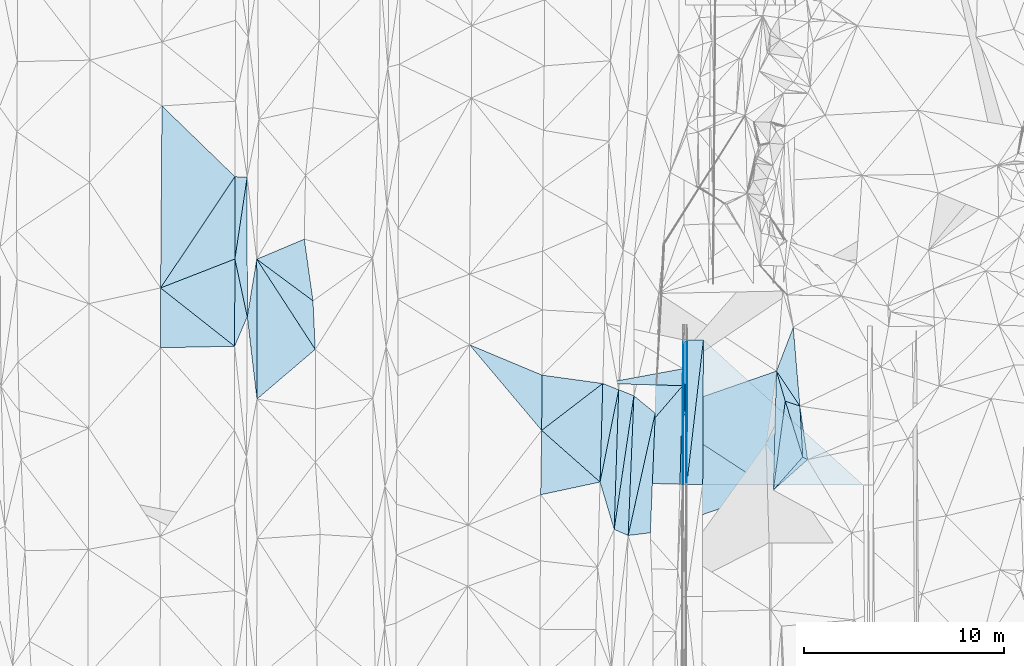
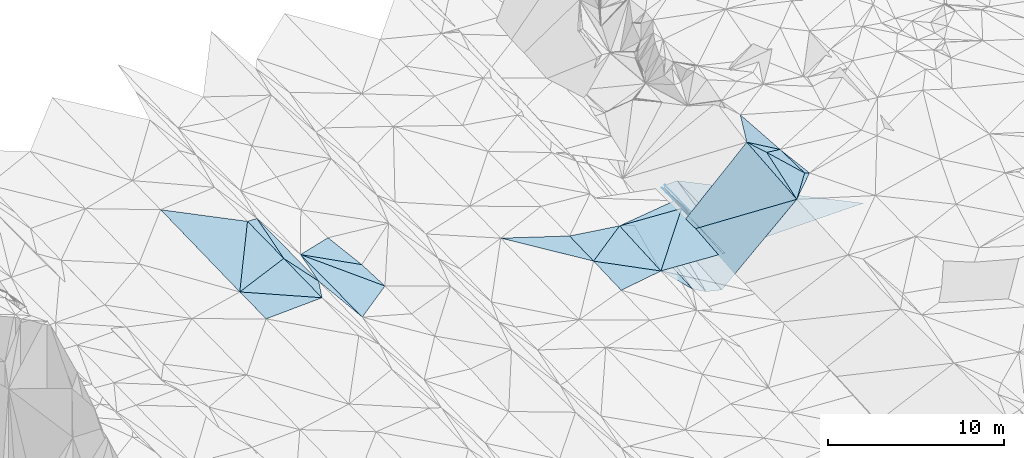
# One storey, part 147 of 275: 45 plates.
"""IFC2X3 building model written with IfcOpenShell, lengths in millimetres."""

from ifc_helpers import new_model, si_unit, frame, origin_with_axes, place, context, subcontext, project, spatial, polyline, outline, extrude, material, type_object, element, save


model = new_model("IFC2X3")

# Units and contexts
model_context = context("Model", 3, precision=1e-05, world=origin_with_axes())
body_context = subcontext(model_context, "Body", "Model", "MODEL_VIEW")
ifc_project = project(units=[si_unit("LENGTHUNIT", "METRE", prefix="MILLI"), si_unit("AREAUNIT", "SQUARE_METRE"), si_unit("VOLUMEUNIT", "CUBIC_METRE"), si_unit("MASSUNIT", "GRAM", prefix="KILO"), si_unit("TIMEUNIT", "SECOND"), si_unit("PLANEANGLEUNIT", "RADIAN"), si_unit("SOLIDANGLEUNIT", "STERADIAN"), si_unit("THERMODYNAMICTEMPERATUREUNIT", "DEGREE_CELSIUS"), si_unit("LUMINOUSINTENSITYUNIT", "LUMEN")], contexts=[model_context])

# Site, building, storey
site_placement = place(None, origin_with_axes())
site = spatial("IfcSite", under=ifc_project, at=site_placement, CompositionType="ELEMENT")
building_placement = place(site_placement, origin_with_axes())
building = spatial("IfcBuilding", under=site, at=building_placement, Name="Undefined", CompositionType="ELEMENT")
storey_placement = place(building_placement, origin_with_axes())
storey = spatial("IfcBuildingStorey", under=building, at=storey_placement, Name="Undefined", CompositionType="ELEMENT", Elevation=0.0)

# Plates
ifc_material = material()
plate_type_1 = type_object("IfcPlateType", PredefinedType="NOTDEFINED")
plate_1_placement = place(storey_placement, frame((-56559.9094753957, 108873.077554814, 43296.3051674812), z_axis=(0.0200615901055505, 0.0163078919971545, -0.999665736764568), x_axis=(0.00478614400087478, 0.999853940724789, 0.0164070119983152)))
element("IfcPlate", 1, at=plate_1_placement, inside=storey, type_object=plate_type_1, material=ifc_material, Name="00_PR", context=body_context, shape_type="SweptSolid", body=[
    extrude(outline(polyline([(0.0, 0.0), (7237.02734375, -3.50992195308208e-08), (7.50920295715332, 8049.544921875), (0.0, 0.0)])), frame((-8.85201319254618e-08, 2.18876761149539e-07, -0.5000001331573), z_axis=(0.0, 0.0, 1.0), x_axis=(1.0, 0.0, 0.0)), (0.0, 0.0, 1.0), 1.0),
])
plate_type_2 = type_object("IfcPlateType", PredefinedType="NOTDEFINED")
plate_2_placement = place(storey_placement, frame((-53025.702382327, 108590.22284917, 45459.5055178758), z_axis=(0.136982781048721, 0.0570289209875159, -0.988930442380635), x_axis=(0.133069726315473, 0.988232827930572, 0.0754209900403692)))
element("IfcPlate", 2, at=plate_2_placement, inside=storey, type_object=plate_type_2, material=ifc_material, Name="00", context=body_context, shape_type="SweptSolid", body=[
    extrude(outline(polyline([(0.0, 0.0), (4508.02880859375, -2.83034751191735e-09), (1859.37231445313, 1250.28735351563), (0.0, 0.0)])), frame((-8.85201319254618e-08, 2.18876761149539e-07, -0.5000001331573), z_axis=(0.0, 0.0, 1.0), x_axis=(1.0, 0.0, 0.0)), (0.0, 0.0, 1.0), 1.0),
])
plate_type_3 = type_object("IfcPlateType", PredefinedType="NOTDEFINED")
plate_3_placement = place(storey_placement, frame((-61564.7340674209, 113931.656635137, 43369.5003387347), z_axis=(-0.031872588093032, 0.0183197905834764, -0.999324033235081), x_axis=(0.983091267140744, 0.18095706105248, -0.028037519984031)))
element("IfcPlate", 3, at=plate_3_placement, inside=storey, type_object=plate_type_3, material=ifc_material, Name="00_PR", context=body_context, shape_type="SweptSolid", body=[
    extrude(outline(polyline([(0.0, 0.0), (4091.7314453125, -9.50240064412355e-09), (3914.64038085938, 832.093811035156), (0.0, 0.0)])), frame((-8.85201319254618e-08, 2.18876761149539e-07, -0.5000001331573), z_axis=(0.0, 0.0, 1.0), x_axis=(1.0, 0.0, 0.0)), (0.0, 0.0, 1.0), 1.0),
])
plate_type_4 = type_object("IfcPlateType", PredefinedType="NOTDEFINED")
plate_4_placement = place(storey_placement, frame((-57566.2411546469, 113821.823646722, 43239.9583379876), z_axis=(-0.0318749769075172, 0.0182345515766572, -0.999325516023655), x_axis=(-0.650509884848787, -0.759466524871226, 0.00689110397837056)))
element("IfcPlate", 4, at=plate_4_placement, inside=storey, type_object=plate_type_4, material=ifc_material, Name="00_PR", context=body_context, shape_type="SweptSolid", body=[
    extrude(outline(polyline([(0.0, 0.0), (6355.1494140625, -1.87283148989081e-08), (2518.53735351563, 3110.26684570313), (0.0, 0.0)])), frame((-8.85201319254618e-08, 2.18876761149539e-07, -0.5000001331573), z_axis=(0.0, 0.0, 1.0), x_axis=(1.0, 0.0, 0.0)), (0.0, 0.0, 1.0), 1.0),
])
plate_type_5 = type_object("IfcPlateType", PredefinedType="NOTDEFINED")
plate_5_placement = place(storey_placement, frame((-61700.3286359968, 108995.300084847, 43283.7523294641), z_axis=(-0.0315213256093392, 0.0179314852149467, -0.999342217596063), x_axis=(0.650509884845149, 0.759466524874353, -0.00689110397720621)))
element("IfcPlate", 5, at=plate_5_placement, inside=storey, type_object=plate_type_5, material=ifc_material, Name="00_PR", context=body_context, shape_type="SweptSolid", body=[
    extrude(outline(polyline([(0.0, 0.0), (6355.1494140625, -1.87283148989081e-08), (2516.81982421875, 3111.59790039063), (0.0, 0.0)])), frame((-8.85201319254618e-08, 2.18876761149539e-07, -0.5000001331573), z_axis=(0.0, 0.0, 1.0), x_axis=(1.0, 0.0, 0.0)), (0.0, 0.0, 1.0), 1.0),
])
plate_type_6 = type_object("IfcPlateType", PredefinedType="NOTDEFINED")
plate_6_placement = place(storey_placement, frame((-57541.6876743928, 114672.07483175, 43255.1567316747), z_axis=(0.97014205143925, -0.000664742498379552, -0.242536508894339), x_axis=(0.0281062970175197, 0.993567110422901, 0.109701564044688)))
element("IfcPlate", 6, at=plate_6_placement, inside=storey, type_object=plate_type_6, material=ifc_material, Name="00_PR", context=body_context, shape_type="SweptSolid", body=[
    extrude(outline(polyline([(0.0, 0.0), (1284.78564453125, -4.48198989033699e-09), (-5754.66259765625, 680.785278320313), (0.0, 0.0)])), frame((-8.85201319254618e-08, 2.18876761149539e-07, -0.5000001331573), z_axis=(0.0, 0.0, 1.0), x_axis=(1.0, 0.0, 0.0)), (0.0, 0.0, 1.0), 1.0),
])
plate_7_placement = place(storey_placement, frame((-57541.6876743928, 114672.07483175, 43255.1567316747), z_axis=(0.970141058159166, -0.000664759863565607, -0.24254048191619), x_axis=(0.000390214973503227, -0.999990671851025, 0.00430162099806109)))
element("IfcPlate", 7, at=plate_7_placement, inside=storey, type_object=plate_type_6, material=ifc_material, Name="00_PR", context=body_context, shape_type="SweptSolid", body=[
    extrude(outline(polyline([(0.0, 0.0), (5794.7919921875, -1.07320374809206e-09), (5792.109375, 123.645538330078), (0.0, 0.0)])), frame((-8.85201319254618e-08, 2.18876761149539e-07, -0.5000001331573), z_axis=(0.0, 0.0, 1.0), x_axis=(1.0, 0.0, 0.0)), (0.0, 0.0, 1.0), 1.0),
])
plate_type_7 = type_object("IfcPlateType", PredefinedType="NOTDEFINED")
plate_8_placement = place(storey_placement, frame((-57506.0621338796, 115948.60418002, 43395.72106721), z_axis=(8.71486001612448e-05, 0.0164040720423197, -0.999865440359628), x_axis=(0.0164193319999173, -0.999730679449421, -0.0164004300027693)))
element("IfcPlate", 8, at=plate_8_placement, inside=storey, type_object=plate_type_7, material=ifc_material, Name="00_PR", context=body_context, shape_type="SweptSolid", body=[
    extrude(outline(polyline([(0.0, 0.0), (7073.96044921875, 4.65661287307739e-10), (7070.701171875, 149.965759277344), (0.0, 0.0)])), frame((-8.85201319254618e-08, 2.18876761149539e-07, -0.5000001331573), z_axis=(0.0, 0.0, 1.0), x_axis=(1.0, 0.0, 0.0)), (0.0, 0.0, 1.0), 1.0),
])
plate_9_placement = place(storey_placement, frame((-57506.0621338796, 115948.60418002, 43395.72106721), z_axis=(0.000108002750360124, 0.0164041444367086, -0.999865437136771), x_axis=(0.674741321812781, 0.737953789828376, 0.0121800129835136)))
element("IfcPlate", 9, at=plate_9_placement, inside=storey, type_object=plate_type_7, material=ifc_material, Name="00_PR", context=body_context, shape_type="SweptSolid", body=[
    extrude(outline(polyline([(0.0, 0.0), (223.480865478516, 2.61934474110603e-10), (-5141.89208984375, 4858.1748046875), (0.0, 0.0)])), frame((-8.85201319254618e-08, 2.18876761149539e-07, -0.5000001331573), z_axis=(0.0, 0.0, 1.0), x_axis=(1.0, 0.0, 0.0)), (0.0, 0.0, 1.0), 1.0),
])
plate_type_8 = type_object("IfcPlateType", PredefinedType="NOTDEFINED")
plate_10_placement = place(storey_placement, frame((-57542.1509980712, 114672.083254713, 43254.7785386739), z_axis=(0.0434943675929681, 0.0161807870784068, -0.998922630696297), x_axis=(-0.0047862770141317, -0.999853985013347, -0.0164042739941027)))
element("IfcPlate", 10, at=plate_10_placement, inside=storey, type_object=plate_type_8, material=ifc_material, Name="00_PR", context=body_context, shape_type="SweptSolid", body=[
    extrude(outline(polyline([(0.0, 0.0), (5793.42919921875, -3.92756192013621e-08), (850.494689941406, 20.0009212493896), (0.0, 0.0)])), frame((-8.85201319254618e-08, 2.18876761149539e-07, -0.5000001331573), z_axis=(0.0, 0.0, 1.0), x_axis=(1.0, 0.0, 0.0)), (0.0, 0.0, 1.0), 1.0),
])
plate_type_9 = type_object("IfcPlateType", PredefinedType="NOTDEFINED")
plate_11_placement = place(storey_placement, frame((-57506.0473725171, 115948.6041072, 43276.6102854014), z_axis=(0.0296062397546576, 0.016255470394761, -0.999429452362614), x_axis=(-0.0282728290321434, -0.999454082377336, -0.0170934010014322)))
element("IfcPlate", 11, at=plate_11_placement, inside=storey, type_object=plate_type_9, material=ifc_material, Name="00_PR", context=body_context, shape_type="SweptSolid", body=[
    extrude(outline(polyline([(0.0, 0.0), (1277.21801757813, -4.40923031419516e-09), (-165.004837036133, 33.8989753723145), (0.0, 0.0)])), frame((-8.85201319254618e-08, 2.18876761149539e-07, -0.5000001331573), z_axis=(0.0, 0.0, 1.0), x_axis=(1.0, 0.0, 0.0)), (0.0, 0.0, 1.0), 1.0),
])
plate_12_placement = place(storey_placement, frame((-57325.2602877436, 116113.361240939, 43399.0431664124), z_axis=(0.0200810104117141, 0.0163055986180557, -0.999665384253427), x_axis=(-0.0047862770141317, -0.999853985013347, -0.0164042739941027)))
element("IfcPlate", 12, at=plate_12_placement, inside=storey, type_object=plate_type_9, material=ifc_material, Name="00_PR", context=body_context, shape_type="SweptSolid", body=[
    extrude(outline(polyline([(0.0, 0.0), (7237.9951171875, 2.11512087844312e-08), (-0.00799687579274178, 30.0065059661865), (0.0, 0.0)])), frame((-8.85201319254618e-08, 2.18876761149539e-07, -0.5000001331573), z_axis=(0.0, 0.0, 1.0), x_axis=(1.0, 0.0, 0.0)), (0.0, 0.0, 1.0), 1.0),
])
plate_13_placement = place(storey_placement, frame((-57389.9024439034, 108876.548616572, 43279.7051689507), z_axis=(0.0200618970811728, 0.0163056173507373, -0.999665767708546), x_axis=(0.00478621599944913, 0.999853976363839, 0.0164048189818349)))
element("IfcPlate", 13, at=plate_13_placement, inside=storey, type_object=plate_type_9, material=ifc_material, Name="00_PR", context=body_context, shape_type="SweptSolid", body=[
    extrude(outline(polyline([(0.0, 0.0), (7238.03076171875, 4.33428795076907e-08), (0.0278349369764328, 30.0057830810547), (0.0, 0.0)])), frame((-8.85201319254618e-08, 2.18876761149539e-07, -0.5000001331573), z_axis=(0.0, 0.0, 1.0), x_axis=(1.0, 0.0, 0.0)), (0.0, 0.0, 1.0), 1.0),
])
plate_type_10 = type_object("IfcPlateType", PredefinedType="NOTDEFINED")
plate_14_placement = place(storey_placement, frame((-57569.8858779446, 108879.50010041, 43159.7413161751), z_axis=(0.0316447606239588, 0.0161968292202808, -0.999367936171789), x_axis=(-0.999106465482098, 0.028538662990022, -0.0311739530154894)))
element("IfcPlate", 14, at=plate_14_placement, inside=storey, type_object=plate_type_10, material=ifc_material, Name="00_PR", context=body_context, shape_type="SweptSolid", body=[
    extrude(outline(polyline([(0.0, 0.0), (132.097457885742, -2.47382558882236e-10), (134.873397827148, 4941.13427734375), (0.0, 0.0)])), frame((-8.85201319254618e-08, 2.18876761149539e-07, -0.5000001331573), z_axis=(0.0, 0.0, 1.0), x_axis=(1.0, 0.0, 0.0)), (0.0, 0.0, 1.0), 1.0),
])
plate_type_11 = type_object("IfcPlateType", PredefinedType="NOTDEFINED")
plate_15_placement = place(storey_placement, frame((-61700.3298359356, 108995.299158409, 43279.5003424583), z_axis=(-0.0336503728996484, 0.0160114540032041, -0.999305401638767), x_axis=(-0.977366811814585, -0.209476972524514, 0.0295552557992385)))
element("IfcPlate", 15, at=plate_15_placement, inside=storey, type_object=plate_type_11, material=ifc_material, Name="00", context=body_context, shape_type="SweptSolid", body=[
    extrude(outline(polyline([(0.0, 0.0), (3045.1435546875, -5.73345459997654e-09), (2322.05786132813, 3144.36743164063), (0.0, 0.0)])), frame((-8.85201319254618e-08, 2.18876761149539e-07, -0.5000001331573), z_axis=(0.0, 0.0, 1.0), x_axis=(1.0, 0.0, 0.0)), (0.0, 0.0, 1.0), 1.0),
])
plate_type_12 = type_object("IfcPlateType", PredefinedType="NOTDEFINED")
plate_16_placement = place(storey_placement, frame((-56525.2720170413, 116109.048059922, 43415.0431675698), z_axis=(0.0200615901055505, 0.0163078919971545, -0.999665736764568), x_axis=(-0.00478614402044619, -0.999853940724827, -0.0164070119903158)))
element("IfcPlate", 16, at=plate_16_placement, inside=storey, type_object=plate_type_12, material=ifc_material, Name="00_PR", context=body_context, shape_type="SweptSolid", body=[
    extrude(outline(polyline([(0.0, 0.0), (7237.02734375, -3.50992195308208e-08), (7237.77392578125, 800.160034179688), (0.0, 0.0)])), frame((-8.85201319254618e-08, 2.18876761149539e-07, -0.5000001331573), z_axis=(0.0, 0.0, 1.0), x_axis=(1.0, 0.0, 0.0)), (0.0, 0.0, 1.0), 1.0),
])
plate_17_placement = place(storey_placement, frame((-57359.9028967669, 108876.423013428, 43280.3051665341), z_axis=(0.0200810104117141, 0.0163055986180557, -0.999665384253427), x_axis=(0.00478621599944913, 0.999853976363839, 0.0164048189818349)))
element("IfcPlate", 17, at=plate_17_placement, inside=storey, type_object=plate_type_12, material=ifc_material, Name="00_PR", context=body_context, shape_type="SweptSolid", body=[
    extrude(outline(polyline([(0.0, 0.0), (7237.9951171875, 2.11512087844312e-08), (7237.77392578125, 800.159851074219), (0.0, 0.0)])), frame((-8.85201319254618e-08, 2.18876761149539e-07, -0.5000001331573), z_axis=(0.0, 0.0, 1.0), x_axis=(1.0, 0.0, 0.0)), (0.0, 0.0, 1.0), 1.0),
])
plate_type_13 = type_object("IfcPlateType", PredefinedType="NOTDEFINED")
plate_18_placement = place(storey_placement, frame((-52866.5394880379, 114551.624411955, 45750.5104493135), z_axis=(0.197561966360912, 0.0489440177551858, -0.979067797741091), x_axis=(0.355493649309711, 0.927189514081718, 0.118084166073915)))
element("IfcPlate", 18, at=plate_18_placement, inside=storey, type_object=plate_type_13, material=ifc_material, Name="00", context=body_context, shape_type="SweptSolid", body=[
    extrude(outline(polyline([(0.0, 0.0), (2362.72143554688, -1.17579475045204e-08), (-1189.66076660156, 1746.19018554688), (0.0, 0.0)])), frame((-8.85201319254618e-08, 2.18876761149539e-07, -0.5000001331573), z_axis=(0.0, 0.0, 1.0), x_axis=(1.0, 0.0, 0.0)), (0.0, 0.0, 1.0), 1.0),
])
plate_type_14 = type_object("IfcPlateType", PredefinedType="NOTDEFINED")
plate_19_placement = place(storey_placement, frame((-64626.5653119508, 111583.077539829, 43419.5006351071), z_axis=(-0.04572592766013, 0.0220578004179306, -0.998710465039965), x_axis=(-0.643676725618658, 0.763893098718301, 0.0463422768904888)))
element("IfcPlate", 19, at=plate_19_placement, inside=storey, type_object=plate_type_14, material=ifc_material, Name="00", context=body_context, shape_type="SweptSolid", body=[
    extrude(outline(polyline([(0.0, 0.0), (5610.427734375, 2.36650521401316e-08), (2100.267578125, 1800.68762207031), (0.0, 0.0)])), frame((-8.85201319254618e-08, 2.18876761149539e-07, -0.5000001331573), z_axis=(0.0, 0.0, 1.0), x_axis=(1.0, 0.0, 0.0)), (0.0, 0.0, 1.0), 1.0),
])
plate_type_15 = type_object("IfcPlateType", PredefinedType="NOTDEFINED")
plate_20_placement = place(storey_placement, frame((-60994.8887578139, 106625.212762836, 43220.5259557587), z_axis=(-0.31707448824831, 0.0250206523563712, -0.948070533166037), x_axis=(0.032295426454886, 0.999357033452528, 0.0155732180059018)))
element("IfcPlate", 20, at=plate_20_placement, inside=storey, type_object=plate_type_15, material=ifc_material, Name="00", context=body_context, shape_type="SweptSolid", body=[
    extrude(outline(polyline([(0.0, 0.0), (6999.19580078125, 2.98750819638371e-08), (6715.134765625, 813.955322265625), (0.0, 0.0)])), frame((-8.85201319254618e-08, 2.18876761149539e-07, -0.5000001331573), z_axis=(0.0, 0.0, 1.0), x_axis=(1.0, 0.0, 0.0)), (0.0, 0.0, 1.0), 1.0),
])
plate_type_16 = type_object("IfcPlateType", PredefinedType="NOTDEFINED")
plate_21_placement = place(storey_placement, frame((-60006.5145235372, 113315.127457879, 43066.5266312213), z_axis=(-0.321051814368409, 0.0256394825463642, -0.946714502595955), x_axis=(-0.0410489374726129, -0.999070772562197, -0.0131368239824262)))
element("IfcPlate", 21, at=plate_21_placement, inside=storey, type_object=plate_type_16, material=ifc_material, Name="00", context=body_context, shape_type="SweptSolid", body=[
    extrude(outline(polyline([(0.0, 0.0), (7003.21484375, 4.13856469094753e-08), (6722.24658203125, 752.966064453125), (0.0, 0.0)])), frame((-8.85201319254618e-08, 2.18876761149539e-07, -0.5000001331573), z_axis=(0.0, 0.0, 1.0), x_axis=(1.0, 0.0, 0.0)), (0.0, 0.0, 1.0), 1.0),
])
plate_type_17 = type_object("IfcPlateType", PredefinedType="NOTDEFINED")
plate_22_placement = place(storey_placement, frame((-79988.1537089693, 120164.495928515, 43779.5000659987), z_axis=(0.00690125327352194, 0.0159963170397201, -0.999848233755713), x_axis=(0.209784061509729, -0.97764472256627, -0.0141930960260311)))
element("IfcPlate", 22, at=plate_22_placement, inside=storey, type_object=plate_type_17, material=ifc_material, Name="00", context=body_context, shape_type="SweptSolid", body=[
    extrude(outline(polyline([(0.0, 0.0), (2959.18530273438, 9.24046617001295e-10), (4269.259765625, 931.032653808594), (0.0, 0.0)])), frame((-8.85201319254618e-08, 2.18876761149539e-07, -0.5000001331573), z_axis=(0.0, 0.0, 1.0), x_axis=(1.0, 0.0, 0.0)), (0.0, 0.0, 1.0), 1.0),
])
plate_type_18 = type_object("IfcPlateType", PredefinedType="NOTDEFINED")
plate_23_placement = place(storey_placement, frame((-51694.288643451, 112800.0848016, 45899.5010172571), z_axis=(0.0306274506880888, 0.0565127638486831, -0.997931995071073), x_axis=(0.142853734652481, -0.988398416810039, -0.0515885660127104)))
element("IfcPlate", 23, at=plate_23_placement, inside=storey, type_object=plate_type_18, material=ifc_material, Name="00", context=body_context, shape_type="SweptSolid", body=[
    extrude(outline(polyline([(0.0, 0.0), (2713.77954101563, -3.49245965480804e-09), (2547.92236328125, 223.13981628418), (0.0, 0.0)])), frame((-8.85201319254618e-08, 2.18876761149539e-07, -0.5000001331573), z_axis=(0.0, 0.0, 1.0), x_axis=(1.0, 0.0, 0.0)), (0.0, 0.0, 1.0), 1.0),
])
plate_type_19 = type_object("IfcPlateType", PredefinedType="NOTDEFINED")
plate_24_placement = place(storey_placement, frame((-79373.1202049505, 124268.645643012, 43851.5000742947), z_axis=(0.00830066301676551, 0.0162963791122434, -0.999832749524295), x_axis=(0.000822662586540412, -0.999866968970308, -0.0162901070713995)))
element("IfcPlate", 24, at=plate_24_placement, inside=storey, type_object=plate_type_19, material=ifc_material, Name="00", context=body_context, shape_type="SweptSolid", body=[
    extrude(outline(polyline([(0.0, 0.0), (6998.1123046875, 8.67294147610664e-09), (4104.2705078125, 618.430725097656), (0.0, 0.0)])), frame((-8.85201319254618e-08, 2.18876761149539e-07, -0.5000001331573), z_axis=(0.0, 0.0, 1.0), x_axis=(1.0, 0.0, 0.0)), (0.0, 0.0, 1.0), 1.0),
])
plate_type_20 = type_object("IfcPlateType", PredefinedType="NOTDEFINED")
plate_25_placement = place(storey_placement, frame((-79985.1366621546, 124287.819214627, 43849.5000632661), z_axis=(0.0037990806290023, 0.0169712506614067, -0.99984876038197), x_axis=(0.999504304823542, -0.031312554443461, 0.0032662782234215)))
element("IfcPlate", 25, at=plate_25_placement, inside=storey, type_object=plate_type_20, material=ifc_material, Name="00", context=body_context, shape_type="SweptSolid", body=[
    extrude(outline(polyline([(0.0, 0.0), (612.317749023438, 1.97906047105789e-09), (125.866027832031, 4121.99658203125), (0.0, 0.0)])), frame((-8.85201319254618e-08, 2.18876761149539e-07, -0.5000001331573), z_axis=(0.0, 0.0, 1.0), x_axis=(1.0, 0.0, 0.0)), (0.0, 0.0, 1.0), 1.0),
])
plate_type_21 = type_object("IfcPlateType", PredefinedType="NOTDEFINED")
plate_26_placement = place(storey_placement, frame((-60006.5063389537, 113315.127154136, 43066.5239282013), z_axis=(-0.304673448070488, 0.0250377217680475, -0.952127723853006), x_axis=(0.749027058546164, -0.611185638724215, -0.255754922890947)))
element("IfcPlate", 26, at=plate_26_placement, inside=storey, type_object=plate_type_21, material=ifc_material, Name="00", context=body_context, shape_type="SweptSolid", body=[
    extrude(outline(polyline([(0.0, 0.0), (1427.1474609375, 2.49565346166492e-09), (4084.490234375, 5688.7568359375), (0.0, 0.0)])), frame((-8.85201319254618e-08, 2.18876761149539e-07, -0.5000001331573), z_axis=(0.0, 0.0, 1.0), x_axis=(1.0, 0.0, 0.0)), (0.0, 0.0, 1.0), 1.0),
])
plate_type_22 = type_object("IfcPlateType", PredefinedType="NOTDEFINED")
plate_27_placement = place(storey_placement, frame((-58937.5319791942, 112442.874553948, 42701.523201707), z_axis=(-0.300157686655758, 0.0239724626411264, -0.953588320071289), x_axis=(-0.0411047754456117, -0.999080627954733, -0.0121776960523076)))
element("IfcPlate", 27, at=plate_27_placement, inside=storey, type_object=plate_type_22, material=ifc_material, Name="00", context=body_context, shape_type="SweptSolid", body=[
    extrude(outline(polyline([(0.0, 0.0), (5994.56591796875, -2.00088834390044e-08), (6171.25634765625, 1157.16101074219), (0.0, 0.0)])), frame((-8.85201319254618e-08, 2.18876761149539e-07, -0.5000001331573), z_axis=(0.0, 0.0, 1.0), x_axis=(1.0, 0.0, 0.0)), (0.0, 0.0, 1.0), 1.0),
])
plate_type_23 = type_object("IfcPlateType", PredefinedType="NOTDEFINED")
plate_28_placement = place(storey_placement, frame((-51694.2348956005, 112800.060644301, 45899.5047926816), z_axis=(0.138121241869745, 0.00819702262256691, -0.990381407016754), x_axis=(-0.940327868474334, 0.315059940480213, -0.128533006170087)))
element("IfcPlate", 28, at=plate_28_placement, inside=storey, type_object=plate_type_23, material=ifc_material, Name="00", context=body_context, shape_type="SweptSolid", body=[
    extrude(outline(polyline([(0.0, 0.0), (778.01025390625, -1.51339918375015e-09), (1673.37121582031, 1290.07824707031), (0.0, 0.0)])), frame((-8.85201319254618e-08, 2.18876761149539e-07, -0.5000001331573), z_axis=(0.0, 0.0, 1.0), x_axis=(1.0, 0.0, 0.0)), (0.0, 0.0, 1.0), 1.0),
])
plate_type_24 = type_object("IfcPlateType", PredefinedType="NOTDEFINED")
plate_29_placement = place(storey_placement, frame((-76077.7636740015, 118070.885459049, 43250.5048516854), z_axis=(-0.13856850283029, 0.0122919138876546, -0.990276566862182), x_axis=(0.0464081485028553, -0.998743920599472, -0.0188908659974352)))
element("IfcPlate", 29, at=plate_29_placement, inside=storey, type_object=plate_type_24, material=ifc_material, Name="00", context=body_context, shape_type="SweptSolid", body=[
    extrude(outline(polyline([(0.0, 0.0), (2435.03930664063, 3.14321368932724e-09), (-2218.97045898438, 2743.22119140625), (0.0, 0.0)])), frame((-8.85201319254618e-08, 2.18876761149539e-07, -0.5000001331573), z_axis=(0.0, 0.0, 1.0), x_axis=(1.0, 0.0, 0.0)), (0.0, 0.0, 1.0), 1.0),
])
plate_type_25 = type_object("IfcPlateType", PredefinedType="NOTDEFINED")
plate_30_placement = place(storey_placement, frame((-78883.7301373464, 113150.128246226, 43581.5114011341), z_axis=(-0.212121893932939, 0.0120897153525215, -0.977168430157769), x_axis=(-0.116492823572364, 0.992480794280937, 0.0375672069712071)))
element("IfcPlate", 30, at=plate_30_placement, inside=storey, type_object=plate_type_25, material=ifc_material, Name="00", context=body_context, shape_type="SweptSolid", body=[
    extrude(outline(polyline([(0.0, 0.0), (4152.55810546875, 1.54541339725256e-08), (6955.63134765625, 823.952026367188), (0.0, 0.0)])), frame((-8.85201319254618e-08, 2.18876761149539e-07, -0.5000001331573), z_axis=(0.0, 0.0, 1.0), x_axis=(1.0, 0.0, 0.0)), (0.0, 0.0, 1.0), 1.0),
])
plate_type_26 = type_object("IfcPlateType", PredefinedType="NOTDEFINED")
plate_31_placement = place(storey_placement, frame((-51306.597655813, 110117.821449544, 45759.5047278297), z_axis=(0.0654846265587762, 0.120830075236208, -0.990510906857098), x_axis=(-0.741249594568231, -0.658647861514922, -0.1293523601418)))
element("IfcPlate", 31, at=plate_31_placement, inside=storey, type_object=plate_type_26, material=ifc_material, Name="00", context=body_context, shape_type="SweptSolid", body=[
    extrude(outline(polyline([(0.0, 0.0), (2319.24633789063, 3.60887497663498e-09), (93.9356842041016, 261.679351806641), (0.0, 0.0)])), frame((-8.85201319254618e-08, 2.18876761149539e-07, -0.5000001331573), z_axis=(0.0, 0.0, 1.0), x_axis=(1.0, 0.0, 0.0)), (0.0, 0.0, 1.0), 1.0),
])
plate_type_27 = type_object("IfcPlateType", PredefinedType="NOTDEFINED")
plate_32_placement = place(storey_placement, frame((-51550.9913001016, 110250.267638809, 45759.5070917644), z_axis=(0.155813747163314, 0.0628779926666756, -0.985783157815722), x_axis=(-0.29868282264539, 0.954254714863762, 0.0136568889891371)))
element("IfcPlate", 32, at=plate_32_placement, inside=storey, type_object=plate_type_27, material=ifc_material, Name="00", context=body_context, shape_type="SweptSolid", body=[
    extrude(outline(polyline([(0.0, 0.0), (2928.9248046875, -8.36371327750385e-09), (2477.87182617188, 633.917419433594), (0.0, 0.0)])), frame((-8.85201319254618e-08, 2.18876761149539e-07, -0.5000001331573), z_axis=(0.0, 0.0, 1.0), x_axis=(1.0, 0.0, 0.0)), (0.0, 0.0, 1.0), 1.0),
])
plate_type_28 = type_object("IfcPlateType", PredefinedType="NOTDEFINED")
plate_33_placement = place(storey_placement, frame((-60768.7023003709, 113619.90405394, 43329.5002592543), z_axis=(-0.0281964177495011, 0.0164861242092119, -0.999466442525538), x_axis=(-0.0322954263577511, -0.999357033454874, -0.0155732180568008)))
element("IfcPlate", 33, at=plate_33_placement, inside=storey, type_object=plate_type_28, material=ifc_material, Name="00", context=body_context, shape_type="SweptSolid", body=[
    extrude(outline(polyline([(0.0, 0.0), (6999.19580078125, 2.98750819638371e-08), (4652.4970703125, 782.089538574219), (0.0, 0.0)])), frame((-8.85201319254618e-08, 2.18876761149539e-07, -0.5000001331573), z_axis=(0.0, 0.0, 1.0), x_axis=(1.0, 0.0, 0.0)), (0.0, 0.0, 1.0), 1.0),
])
plate_type_29 = type_object("IfcPlateType", PredefinedType="NOTDEFINED")
plate_34_placement = place(storey_placement, frame((-53025.6475394548, 108590.214658412, 45459.5158712999), z_axis=(0.246679128815039, 0.0406790029547175, -0.968243061491103), x_axis=(0.0266525883803021, 0.998455901247146, 0.0487386171057423)))
element("IfcPlate", 34, at=plate_34_placement, inside=storey, type_object=plate_type_29, material=ifc_material, Name="00", context=body_context, shape_type="SweptSolid", body=[
    extrude(outline(polyline([(0.0, 0.0), (5970.625, 3.28072928823531e-08), (4480.66259765625, 495.969573974609), (0.0, 0.0)])), frame((-8.85201319254618e-08, 2.18876761149539e-07, -0.5000001331573), z_axis=(0.0, 0.0, 1.0), x_axis=(1.0, 0.0, 0.0)), (0.0, 0.0, 1.0), 1.0),
])
plate_type_30 = type_object("IfcPlateType", PredefinedType="NOTDEFINED")
plate_35_placement = place(storey_placement, frame((-61700.3343156473, 108995.30084739, 43279.5005400579), z_axis=(-0.0426035178722954, 0.0193823482137626, -0.998904031848218), x_axis=(0.0274536723338922, 0.999456976741728, 0.0182221710470694)))
element("IfcPlate", 35, at=plate_35_placement, inside=storey, type_object=plate_type_30, material=ifc_material, Name="00", context=body_context, shape_type="SweptSolid", body=[
    extrude(outline(polyline([(0.0, 0.0), (4939.03857421875, 2.30211298912764e-08), (4648.5810546875, 805.038818359375), (0.0, 0.0)])), frame((-8.85201319254618e-08, 2.18876761149539e-07, -0.5000001331573), z_axis=(0.0, 0.0, 1.0), x_axis=(1.0, 0.0, 0.0)), (0.0, 0.0, 1.0), 1.0),
])
plate_type_31 = type_object("IfcPlateType", PredefinedType="NOTDEFINED")
plate_36_placement = place(storey_placement, frame((-61564.7348551798, 113931.658491995, 43369.5003865866), z_axis=(-0.0331623997587151, 0.0219609225384665, -0.999208673462907), x_axis=(-0.793391777235806, -0.608573434234907, 0.0129561938137545)))
element("IfcPlate", 36, at=plate_36_placement, inside=storey, type_object=plate_type_31, material=ifc_material, Name="00", context=body_context, shape_type="SweptSolid", body=[
    extrude(outline(polyline([(0.0, 0.0), (3859.15795898438, -3.69618646800518e-09), (2157.95776367188, 2181.63208007813), (0.0, 0.0)])), frame((-8.85201319254618e-08, 2.18876761149539e-07, -0.5000001331573), z_axis=(0.0, 0.0, 1.0), x_axis=(1.0, 0.0, 0.0)), (0.0, 0.0, 1.0), 1.0),
])
plate_type_32 = type_object("IfcPlateType", PredefinedType="NOTDEFINED")
plate_37_placement = place(storey_placement, frame((-64626.5579236422, 111583.076044964, 43419.5003206789), z_axis=(-0.0309471119683098, 0.0190700951413645, -0.999339085462047), x_axis=(0.793391777233479, 0.608573434238017, -0.0129561938102005)))
element("IfcPlate", 37, at=plate_37_placement, inside=storey, type_object=plate_type_32, material=ifc_material, Name="00", context=body_context, shape_type="SweptSolid", body=[
    extrude(outline(polyline([(0.0, 0.0), (3859.15795898438, -3.69618646800518e-09), (748.60888671875, 3836.48071289063), (0.0, 0.0)])), frame((-8.85201319254618e-08, 2.18876761149539e-07, -0.5000001331573), z_axis=(0.0, 0.0, 1.0), x_axis=(1.0, 0.0, 0.0)), (0.0, 0.0, 1.0), 1.0),
])
plate_type_33 = type_object("IfcPlateType", PredefinedType="NOTDEFINED")
plate_38_placement = place(storey_placement, frame((-79988.1414632414, 120164.495884976, 43779.500299422), z_axis=(0.0313990756202367, 0.0159065650029169, -0.999380347635475), x_axis=(-0.00335724039886719, -0.999866038898879, -0.01601977507862)))
element("IfcPlate", 38, at=plate_38_placement, inside=storey, type_object=plate_type_33, material=ifc_material, Name="00", context=body_context, shape_type="SweptSolid", body=[
    extrude(outline(polyline([(0.0, 0.0), (4369.599609375, -1.37952156364918e-08), (1463.24621582031, 3719.00659179688), (0.0, 0.0)])), frame((-8.85201319254618e-08, 2.18876761149539e-07, -0.5000001331573), z_axis=(0.0, 0.0, 1.0), x_axis=(1.0, 0.0, 0.0)), (0.0, 0.0, 1.0), 1.0),
])
plate_type_34 = type_object("IfcPlateType", PredefinedType="NOTDEFINED")
plate_39_placement = place(storey_placement, frame((-83708.9787794302, 115720.515251568, 43589.5003145937), z_axis=(0.032019638181031, 0.0166951609831833, -0.999347794499243), x_axis=(-0.00040951761402717, 0.999860618251637, 0.0166906070823765)))
element("IfcPlate", 39, at=plate_39_placement, inside=storey, type_object=plate_type_34, material=ifc_material, Name="00", context=body_context, shape_type="SweptSolid", body=[
    extrude(outline(polyline([(0.0, 0.0), (2995.69702148438, 8.17817635834217e-09), (75.4415435791016, 3708.10034179688), (0.0, 0.0)])), frame((-8.85201319254618e-08, 2.18876761149539e-07, -0.5000001331573), z_axis=(0.0, 0.0, 1.0), x_axis=(1.0, 0.0, 0.0)), (0.0, 0.0, 1.0), 1.0),
])
plate_type_35 = type_object("IfcPlateType", PredefinedType="NOTDEFINED")
plate_40_placement = place(storey_placement, frame((-79985.1230625689, 124287.819199412, 43849.5003023147), z_axis=(0.0309953850875996, 0.0169433134649535, -0.999375910372118), x_axis=(-0.000731973402660732, -0.999855660822263, -0.0169741490688852)))
element("IfcPlate", 40, at=plate_40_placement, inside=storey, type_object=plate_type_35, material=ifc_material, Name="00", context=body_context, shape_type="SweptSolid", body=[
    extrude(outline(polyline([(0.0, 0.0), (4123.91796875, 1.12631823867559e-08), (5577.51123046875, 3722.7900390625), (0.0, 0.0)])), frame((-8.85201319254618e-08, 2.18876761149539e-07, -0.5000001331573), z_axis=(0.0, 0.0, 1.0), x_axis=(1.0, 0.0, 0.0)), (0.0, 0.0, 1.0), 1.0),
])
plate_type_36 = type_object("IfcPlateType", PredefinedType="NOTDEFINED")
plate_41_placement = place(storey_placement, frame((-75964.757958419, 115638.904880793, 43204.504845666), z_axis=(-0.138450165401373, 0.0123703120511347, -0.99029214228938), x_axis=(-0.757301534436231, -0.64569921922049, 0.0978105527976346)))
element("IfcPlate", 41, at=plate_41_placement, inside=storey, type_object=plate_type_36, material=ifc_material, Name="00", context=body_context, shape_type="SweptSolid", body=[
    extrude(outline(polyline([(0.0, 0.0), (3854.38989257813, -3.39641701430082e-08), (-650.987060546875, 5362.95458984375), (0.0, 0.0)])), frame((-8.85201319254618e-08, 2.18876761149539e-07, -0.5000001331573), z_axis=(0.0, 0.0, 1.0), x_axis=(1.0, 0.0, 0.0)), (0.0, 0.0, 1.0), 1.0),
])
plate_type_37 = type_object("IfcPlateType", PredefinedType="NOTDEFINED")
plate_42_placement = place(storey_placement, frame((-78894.50829694, 120153.826240065, 43670.5042117412), z_axis=(-0.126359966815228, 0.0290600549734271, -0.991558708292855), x_axis=(0.916223633948878, 0.386546997568095, -0.105430883827294)))
element("IfcPlate", 42, at=plate_42_placement, inside=storey, type_object=plate_type_37, material=ifc_material, Name="00", context=body_context, shape_type="SweptSolid", body=[
    extrude(outline(polyline([(0.0, 0.0), (2598.85888671875, 1.06811057776213e-08), (1819.9033203125, 3022.75439453125), (0.0, 0.0)])), frame((-8.85201319254618e-08, 2.18876761149539e-07, -0.5000001331573), z_axis=(0.0, 0.0, 1.0), x_axis=(1.0, 0.0, 0.0)), (0.0, 0.0, 1.0), 1.0),
])
plate_type_38 = type_object("IfcPlateType", PredefinedType="NOTDEFINED")
plate_43_placement = place(storey_placement, frame((-83710.2055200969, 118715.794374646, 43639.5003074793), z_axis=(0.0321096939644818, 0.0161975013328033, -0.999353095009007), x_axis=(0.00768716546337959, 0.999835100961533, 0.0164523059897495)))
element("IfcPlate", 43, at=plate_43_placement, inside=storey, type_object=plate_type_38, material=ifc_material, Name="00", context=body_context, shape_type="SweptSolid", body=[
    extrude(outline(polyline([(0.0, 0.0), (9117.2626953125, 4.96074790135026e-08), (5603.19580078125, 3684.01879882813), (0.0, 0.0)])), frame((-8.85201319254618e-08, 2.18876761149539e-07, -0.5000001331573), z_axis=(0.0, 0.0, 1.0), x_axis=(1.0, 0.0, 0.0)), (0.0, 0.0, 1.0), 1.0),
])
plate_type_39 = type_object("IfcPlateType", PredefinedType="NOTDEFINED")
plate_44_placement = place(storey_placement, frame((-59183.5774661784, 106453.804677219, 42628.5461169287), z_axis=(0.419465072100314, -0.00619340383448714, -0.907750348409089), x_axis=(0.0411047754410935, 0.999080627955354, 0.0121776960166401)))
element("IfcPlate", 44, at=plate_44_placement, inside=storey, type_object=plate_type_39, material=ifc_material, Name="00", context=body_context, shape_type="SweptSolid", body=[
    extrude(outline(polyline([(0.0, 0.0), (5994.56591796875, -2.00088834390044e-08), (2422.02124023438, 6680.8447265625), (0.0, 0.0)])), frame((-8.85201319254618e-08, 2.18876761149539e-07, -0.5000001331573), z_axis=(0.0, 0.0, 1.0), x_axis=(1.0, 0.0, 0.0)), (0.0, 0.0, 1.0), 1.0),
])
plate_type_40 = type_object("IfcPlateType", PredefinedType="NOTDEFINED")
plate_45_placement = place(storey_placement, frame((-52866.4184880835, 114551.615981878, 45750.5512000808), z_axis=(0.439666277018565, 0.0320784944307956, -0.897588176753508), x_axis=(-0.0266525884065403, -0.998455901250804, -0.0487386170164475)))
element("IfcPlate", 45, at=plate_45_placement, inside=storey, type_object=plate_type_40, material=ifc_material, Name="00", context=body_context, shape_type="SweptSolid", body=[
    extrude(outline(polyline([(0.0, 0.0), (5970.625, 3.28072928823531e-08), (2415.88623046875, 6690.3359375), (0.0, 0.0)])), frame((-8.85201319254618e-08, 2.18876761149539e-07, -0.5000001331573), z_axis=(0.0, 0.0, 1.0), x_axis=(1.0, 0.0, 0.0)), (0.0, 0.0, 1.0), 1.0),
])

save(model, "model.ifc")
